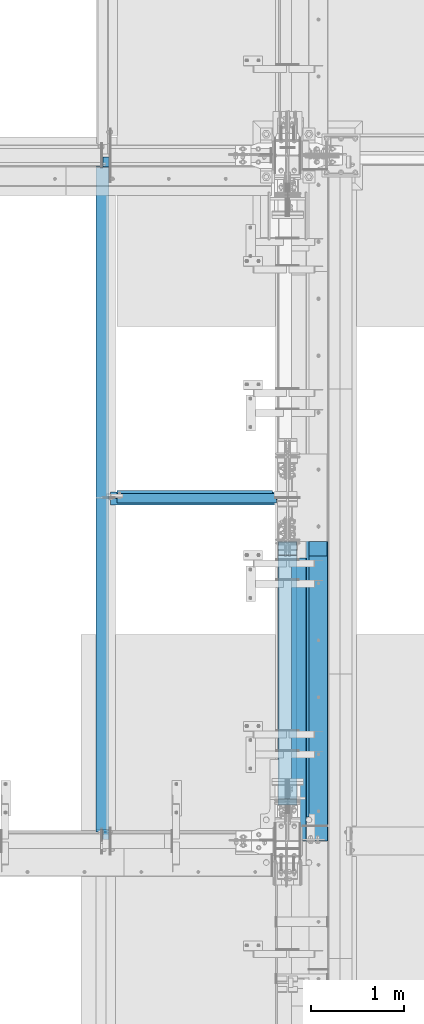
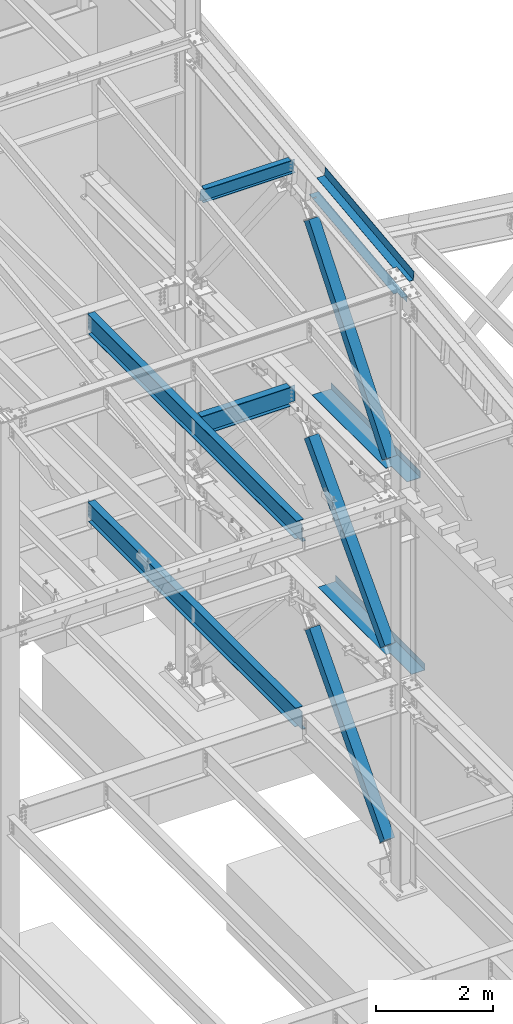
# One storey, part 741 of 1179: 8 beams, 3 members, 10 elements without a shape of their own.
"""IFC2X3 building model written with IfcOpenShell, lengths in millimetres."""

import ifcopenshell
import ifcopenshell.guid

model = None  # the IFC model being written
_history = None  # IfcOwnerHistory: only IFC2X3 demands one
_inside = {}  # id of a spatial element -> (the spatial element, [elements in it])
_under = {}  # id of a project, library or spatial element -> (it, [spatial elements below it])
_declared = {}  # id of a project -> (the project, [libraries it declares])
_typed = {}  # id of a type object -> (the type object, [elements of that type])
_made_of = {}  # id of a material, layer set ... -> (it, [elements and type objects made of it])


def new_model(schema):
    """Start an empty IFC model of exactly this schema.

    Asked for "IFC4X3", IfcOpenShell would pick the latest addendum, in which some entities
    have other attributes; the version numbers below select the first issue.
    IFC2X3 requires an IfcOwnerHistory on every rooted entity: one is made here for all.
    """
    global model, _history
    if schema == "IFC4X3":
        model = ifcopenshell.file(schema_version=(4, 3, 0, 0))
    else:
        model = ifcopenshell.file(schema=schema)
    _inside.clear()
    _under.clear()
    _declared.clear()
    _typed.clear()
    _made_of.clear()
    _history = None
    if model.schema == "IFC2X3":
        org = make("IfcOrganization", Name="unknown")
        user = make(
            "IfcPersonAndOrganization",
            ThePerson=make("IfcPerson", FamilyName="unknown"),
            TheOrganization=org,
        )
        app = make(
            "IfcApplication",
            ApplicationDeveloper=org,
            Version="unknown",
            ApplicationFullName="unknown",
            ApplicationIdentifier="unknown",
        )
        _history = make(
            "IfcOwnerHistory",
            OwningUser=user,
            OwningApplication=app,
            ChangeAction="ADDED",
            CreationDate=0,
        )
    return model


def make(cls, **values):
    """One entity of the class cls with the attributes given. An attribute that is None is left unset."""
    return model.create_entity(
        cls, **{name: value for name, value in values.items() if value is not None}
    )


def rooted(cls, **values):
    """An entity with a GlobalId (a new one), such as an element, a storey or a relation."""
    return make(cls, GlobalId=ifcopenshell.guid.new(), OwnerHistory=_history, **values)


def si_unit(unit_type, name, prefix=None):
    """IfcSIUnit, for example si_unit("LENGTHUNIT", "METRE", prefix="MILLI")."""
    return make("IfcSIUnit", UnitType=unit_type, Prefix=prefix, Name=name)


def assignment(units):
    """IfcUnitAssignment: the units of a project."""
    return None if units is None else make("IfcUnitAssignment", Units=units)


def point(xyz):
    """IfcCartesianPoint."""
    return None if xyz is None else make("IfcCartesianPoint", Coordinates=xyz)


def direction(xyz):
    """IfcDirection."""
    return None if xyz is None else make("IfcDirection", DirectionRatios=xyz)


def frame(location, z_axis=None, x_axis=None):
    """IfcAxis2Placement3D, a coordinate frame: its origin and axes. An axis left out is left unset."""
    return make(
        "IfcAxis2Placement3D",
        Location=point(location),
        Axis=direction(z_axis),
        RefDirection=direction(x_axis),
    )


def origin_with_axes():
    """The frame at (0, 0, 0) with the z axis (0, 0, 1) and the x axis (1, 0, 0) written out."""
    return frame((0.0, 0.0, 0.0), z_axis=(0.0, 0.0, 1.0), x_axis=(1.0, 0.0, 0.0))


def place(relative_to, where):
    """IfcLocalPlacement: puts the frame where relative to a parent placement (None: the world)."""
    return make(
        "IfcLocalPlacement", PlacementRelTo=relative_to, RelativePlacement=where
    )


def context(
    kind, dimensions, precision=None, world=None, true_north=None, identifier=None
):
    """IfcGeometricRepresentationContext, for example the 3D "Model" context."""
    return make(
        "IfcGeometricRepresentationContext",
        ContextIdentifier=identifier,
        ContextType=kind,
        CoordinateSpaceDimension=dimensions,
        Precision=precision,
        WorldCoordinateSystem=world,
        TrueNorth=true_north,
    )


def subcontext(parent, identifier, kind, view, scale=None):
    """IfcGeometricRepresentationSubContext, for example "Body" below "Model"."""
    return make(
        "IfcGeometricRepresentationSubContext",
        ContextIdentifier=identifier,
        ContextType=kind,
        ParentContext=parent,
        TargetScale=scale,
        TargetView=view,
    )


def project(units=None, contexts=None):
    """IfcProject with its units and contexts."""
    return rooted(
        "IfcProject",
        Name="project",
        RepresentationContexts=contexts,
        UnitsInContext=assignment(units),
    )


def spatial(cls, under=None, at=None, **own):
    """A site, building, storey or space (cls), placed at a placement, below another one or the project."""
    s = rooted(cls, ObjectPlacement=at, **own)
    if under is not None:
        _under.setdefault(under.id(), (under, []))[1].append(s)
    return s


def faces_of(points, faces, orient=None, outer=None):
    """IfcFace entities. A face is a list of loops; a loop is a list of indices into points, from 0.

    orient and outer hold one flag for each loop. By default every Orientation is true, the
    first loop of a face is its IfcFaceOuterBound and the others are IfcFaceBound.
    """
    made = []
    for i, loops in enumerate(faces):
        bounds = []
        for j, loop in enumerate(loops):
            is_outer = j == 0 if outer is None else outer[i][j]
            bounds.append(
                make(
                    "IfcFaceOuterBound" if is_outer else "IfcFaceBound",
                    Bound=make("IfcPolyLoop", Polygon=[points[k] for k in loop]),
                    Orientation=True if orient is None else orient[i][j],
                )
            )
        made.append(make("IfcFace", Bounds=bounds))
    return made


def faceted_brep(points, faces, orient=None, outer=None, voids=None):
    """IfcFacetedBrep: a solid bounded by flat faces; with voids (closed shells), ...WithVoids."""
    shared = [point(p) for p in points]
    hull = make("IfcClosedShell", CfsFaces=faces_of(shared, faces, orient, outer))
    if voids is None:
        return make("IfcFacetedBrep", Outer=hull)
    return make(
        "IfcFacetedBrepWithVoids",
        Outer=hull,
        Voids=[
            make(cls, CfsFaces=faces_of(shared, fs, o, b)) for cls, fs, o, b in voids
        ],
    )


def shape(context_of_items, identifier, shape_type, items):
    """IfcShapeRepresentation: the items that make up one representation, for example the "Body"."""
    return make(
        "IfcShapeRepresentation",
        ContextOfItems=context_of_items,
        RepresentationIdentifier=identifier,
        RepresentationType=shape_type,
        Items=items,
    )


def material(Name=None, Category=None):
    """IfcMaterial."""
    return make("IfcMaterial", Name=Name, Category=Category)


def made_of(thing, what):
    """Note that an element or type object is made of a material, layer set ...; save() writes the relation."""
    if what is not None:
        _made_of.setdefault(what.id(), (what, []))[1].append(thing)
    return thing


def type_object(cls, material=None, **own):
    """A type object (cls), such as IfcWallType, which elements share."""
    return made_of(rooted(cls, **own), material)


def element(
    cls,
    number,
    at=None,
    inside=None,
    cuts=None,
    type_object=None,
    material=None,
    context=None,
    identifier="Body",
    shape_type=None,
    held_by="IfcProductDefinitionShape",
    body=None,
    shapes=None,
    **own,
):
    """One element of the class cls, such as IfcWall. Its Tag is "e" and its number.

    at: its placement. inside: the storey or other place that contains it. cuts: it is an
    opening in that element (IfcRelVoidsElement). A single representation is given by context,
    identifier, shape_type and body (its items); several are given by shapes. held_by: the class
    of the entity that holds the representations. save() writes the other relations.
    """
    e = rooted(cls, Tag="e%d" % number, ObjectPlacement=at, **own)
    if body is not None:
        shapes = [shape(context, identifier, shape_type, body)]
    if shapes is not None:
        e.Representation = make(held_by, Representations=shapes)
    if inside is not None:
        _inside.setdefault(inside.id(), (inside, []))[1].append(e)
    if cuts is not None:
        rooted(
            "IfcRelVoidsElement", RelatingBuildingElement=cuts, RelatedOpeningElement=e
        )
    if type_object is not None:
        _typed.setdefault(type_object.id(), (type_object, []))[1].append(e)
    return made_of(e, material)


def aggregate(whole, parts):
    """IfcRelAggregates: a whole, such as a stair, and the parts it consists of."""
    return rooted("IfcRelAggregates", RelatingObject=whole, RelatedObjects=parts)


def save(model, path):
    """Write the relations noted so far, then the file.

    IfcRelAggregates (storeys below a building ...), IfcRelContainedInSpatialStructure (elements
    in a storey), IfcRelDefinesByType, IfcRelAssociatesMaterial and IfcRelDeclares: one each for
    every whole, place, type object, material and project.
    """
    for whole, parts in _under.values():
        aggregate(whole, parts)
    for where, things in _inside.values():
        rooted(
            "IfcRelContainedInSpatialStructure",
            RelatedElements=things,
            RelatingStructure=where,
        )
    for kind, things in _typed.values():
        rooted("IfcRelDefinesByType", RelatedObjects=things, RelatingType=kind)
    for what, things in _made_of.values():
        rooted("IfcRelAssociatesMaterial", RelatedObjects=things, RelatingMaterial=what)
    for by, libraries in _declared.values():
        rooted("IfcRelDeclares", RelatingContext=by, RelatedDefinitions=libraries)
    model.write(path)


model = new_model("IFC2X3")

# Units and contexts
model_context = context("Model", 3, precision=1e-05, world=origin_with_axes())
body_context = subcontext(model_context, "Body", "Model", "MODEL_VIEW")
ifc_project = project(units=[si_unit("LENGTHUNIT", "METRE", prefix="MILLI"), si_unit("AREAUNIT", "SQUARE_METRE"), si_unit("VOLUMEUNIT", "CUBIC_METRE"), si_unit("MASSUNIT", "GRAM", prefix="KILO"), si_unit("TIMEUNIT", "SECOND"), si_unit("PLANEANGLEUNIT", "RADIAN"), si_unit("SOLIDANGLEUNIT", "STERADIAN"), si_unit("THERMODYNAMICTEMPERATUREUNIT", "DEGREE_CELSIUS"), si_unit("LUMINOUSINTENSITYUNIT", "LUMEN")], contexts=[model_context])

# Site, building, storey
site_placement = place(None, origin_with_axes())
site = spatial("IfcSite", under=ifc_project, at=site_placement, CompositionType="ELEMENT")
building_placement = place(site_placement, origin_with_axes())
building = spatial("IfcBuilding", under=site, at=building_placement, Name="Undefined", CompositionType="ELEMENT")
storey_placement = place(building_placement, origin_with_axes())
storey = spatial("IfcBuildingStorey", under=building, at=storey_placement, Name="Undefined", CompositionType="ELEMENT", Elevation=0.0)

# Assembly, beam
assembly_1_placement = place(storey_placement, origin_with_axes())
assembly_1 = element("IfcElementAssembly", 1, at=assembly_1_placement, inside=storey, Name="BEAM", AssemblyPlace="NOTDEFINED", PredefinedType="RIGID_FRAME")
ifc_material_1 = material(Name="STEEL/A992")
beam_type_1 = type_object("IfcBeamType", Name="W16X31", PredefinedType="NOTDEFINED")
beam_1_placement = place(assembly_1_placement, frame((22326.6, 30721.3, 7812.0875), z_axis=(0.0, 0.0, 1.0), x_axis=(1.0, 0.0, 0.0)))
beam_1 = element("IfcBeam", 2, at=beam_1_placement, type_object=beam_type_1, material=ifc_material_1, Name="BEAM", ObjectType="W16X31", context=body_context, shape_type="Brep", body=[
    faceted_brep([(15.875, -3.17499999999927, -169.8625), (15.875, 3.17499999999927, -169.8625), (69.8500001907269, 3.17499999999927, -169.8625), (69.8500001907269, -3.17499999999927, -169.8625), (74.7100797087733, 3.17499999999927, -170.829229922588), (74.7100797087733, -3.17499999999927, -170.829229922588), (78.8302561769269, 3.17499999999927, -173.582243823066), (78.8302561769269, -3.17499999999927, -173.582243823066), (81.5832700774044, 3.17499999999927, -177.70242029122), (81.5832700774044, -3.17499999999927, -177.70242029122), (82.549999999992, -3.17499999999927, -182.562499809265), (82.549999999992, 3.17499999999927, -182.562499809265), (82.549999999992, 3.17499999999927, -190.5), (82.549999999992, 69.8499999999985, -190.5), (82.549999999992, 69.8499999999985, -201.6125), (82.549999999992, -69.8499999999985, -201.6125), (82.549999999992, -69.8499999999985, -190.5), (82.549999999992, -3.17499999999927, -190.5), (1839.11875, 69.8499999999985, 190.5), (1839.11875, 3.17499999999927, 190.5), (82.549999999992, 3.17499999999927, 190.5), (82.549999999992, 69.8499999999985, 190.5), (69.8500001907269, -3.17499999999927, 169.8625), (69.8500001907269, 3.17499999999927, 169.8625), (15.875, 3.17499999999927, 169.8625), (15.875, -3.17499999999927, 169.8625), (74.7100797087733, -3.17499999999927, 170.829229922588), (74.7100797087733, 3.17499999999927, 170.829229922588), (78.8302561769269, -3.17499999999927, 173.582243823066), (78.8302561769269, 3.17499999999927, 173.582243823066), (81.5832700774044, -3.17499999999927, 177.70242029122), (81.5832700774044, 3.17499999999927, 177.70242029122), (82.549999999992, -3.17499999999927, 182.562499809265), (82.549999999992, 3.17499999999927, 182.562499809265), (1839.11875, -69.8499999999985, 201.6125), (1839.11875, 69.8499999999985, 201.6125), (82.549999999992, 69.8499999999985, 201.6125), (82.549999999992, -69.8499999999985, 201.6125), (1839.11875, -69.8499999999985, 190.5), (82.549999999992, -69.8499999999985, 190.5), (1839.11875, -3.17499999999927, 190.5), (82.549999999992, -3.17499999999927, 190.5), (1839.11875, -3.17499999999927, 179.387499809265), (1839.11875, 3.17499999999927, 179.387499809265), (1840.08547992259, -3.17499999999927, 174.52742029122), (1840.08547992259, 3.17499999999927, 174.52742029122), (1842.83849382306, -3.17499999999927, 170.407243823066), (1842.83849382306, 3.17499999999927, 170.407243823066), (1846.95867029122, -3.17499999999927, 167.654229922588), (1846.95867029122, 3.17499999999927, 167.654229922588), (1851.81874980926, -3.17499999999927, 166.6875), (1851.81874980926, 3.17499999999927, 166.6875), (1962.94375, -3.17499999999927, 166.6875), (1962.94375, 3.17499999999927, 166.6875), (1962.94375, -3.17499999999927, -166.6875), (1962.94375, 3.17499999999927, -166.6875), (1851.81874980926, -3.17499999999927, -166.6875), (1851.81874980926, 3.17499999999927, -166.6875), (1846.95867029122, -3.17499999999927, -167.654229922588), (1846.95867029122, 3.17499999999927, -167.654229922588), (1842.83849382306, -3.17499999999927, -170.407243823066), (1842.83849382306, 3.17499999999927, -170.407243823066), (1840.08547992259, -3.17499999999927, -174.52742029122), (1840.08547992259, 3.17499999999927, -174.52742029122), (1839.11875, -3.17499999999927, -179.387499809265), (1839.11875, 3.17499999999927, -179.387499809265), (1839.11875, -3.17499999999927, -190.5), (1839.11875, -69.8499999999985, -190.5), (1839.11875, -69.8499999999985, -201.6125), (1839.11875, 69.8499999999985, -201.6125), (1839.11875, 69.8499999999985, -190.5), (1839.11875, 3.17499999999927, -190.5)], [[[0, 1, 2, 3]], [[3, 2, 4, 5]], [[5, 4, 6, 7]], [[7, 6, 8, 9]], [[10, 11, 12, 13, 14, 15, 16, 17]], [[9, 8, 11, 10]], [[18, 19, 20, 21]], [[22, 23, 24, 25]], [[26, 27, 23, 22]], [[28, 29, 27, 26]], [[30, 31, 29, 28]], [[32, 33, 31, 30]], [[34, 35, 36, 37]], [[38, 34, 37, 39]], [[40, 38, 39, 41]], [[37, 36, 21, 20, 33, 32, 41, 39]], [[35, 18, 21, 36]], [[34, 38, 40, 42, 43, 19, 18, 35]], [[44, 45, 43, 42]], [[46, 47, 45, 44]], [[48, 49, 47, 46]], [[50, 51, 49, 48]], [[52, 53, 51, 50]], [[53, 52, 54, 55]], [[54, 56, 57, 55]], [[58, 59, 57, 56]], [[60, 61, 59, 58]], [[62, 63, 61, 60]], [[64, 65, 63, 62]], [[66, 67, 68, 69, 70, 71, 65, 64]], [[67, 66, 17, 16]], [[68, 67, 16, 15]], [[69, 68, 15, 14]], [[70, 69, 14, 13]], [[71, 70, 13, 12]], [[6, 4, 2, 1, 24, 23, 27, 29, 31, 33, 20, 19, 43, 45, 47, 49, 51, 53, 55, 57, 59, 61, 63, 65, 71, 12, 11, 8]], [[25, 24, 1, 0]], [[66, 64, 62, 60, 58, 56, 54, 52, 50, 48, 46, 44, 42, 40, 41, 32, 30, 28, 26, 22, 25, 0, 3, 5, 7, 9, 10, 17]]]),
])
aggregate(assembly_1, [beam_1])

assembly_2_placement = place(storey_placement, origin_with_axes())
assembly_2 = element("IfcElementAssembly", 3, at=assembly_2_placement, inside=storey, Name="BEAM", AssemblyPlace="NOTDEFINED", PredefinedType="RIGID_FRAME")
beam_2_placement = place(assembly_2_placement, frame((22326.6, 27051.0, 7812.0875), z_axis=(0.0, 0.0, 1.0), x_axis=(0.0, 1.0, 0.0)))
beam_2 = element("IfcBeam", 4, at=beam_2_placement, type_object=beam_type_1, material=ifc_material_1, Name="BEAM", ObjectType="W16X31", context=body_context, shape_type="Brep", body=[
    faceted_brep([(82.5499999999993, -3.17500000000291, 166.6875), (82.5499999999993, 3.17500000000291, 166.6875), (17.4624999999942, 3.17499999999927, 166.6875), (17.4624999999942, -3.17499999999927, 166.6875), (87.4100797087813, -3.17499999999927, 167.654229922588), (87.4100797087813, 3.17497144083973, 167.654229922588), (91.5302561769349, -3.17499999999927, 170.407243823066), (91.5302561769349, 3.17496966460385, 170.407243823066), (94.2832700774125, -3.17499999999927, 174.52742029122), (94.2832700774125, 3.1749670062818, 174.52742029122), (95.25, -3.17499999999927, 179.387499809265), (95.25, 3.1749638705769, 179.387499809265), (95.25, -69.8499999999985, 201.6125), (95.25, 69.8499999999985, 201.6125), (95.25, 69.8499999999985, 190.5), (95.25, 3.17499999999927, 190.5), (95.25, -3.17499999999927, 190.5), (95.25, -69.8499999999985, 190.5), (7196.1375, 3.17499999999927, -190.5), (7196.1375, 69.8500000000004, -190.5), (144.462499999994, 69.8499999999985, -190.5), (144.462499999994, 3.17549991607666, -190.5), (17.4624999999942, -3.17499999999927, -190.5), (17.4624999999942, -69.8499999999985, -190.5), (7323.1375, -69.8500000000004, -190.5), (7323.1375, -3.17499999999927, -190.5), (17.4624999999942, -69.8499999999985, -201.6125), (7323.1375, -69.8500000000004, -201.6125), (7196.1375, 69.8500000000004, -201.6125), (7196.1375, 3.17549991607484, -201.6125), (7323.1375, 3.17549991607484, -201.6125), (17.4624999999942, 3.17549991607666, -201.6125), (144.462499999994, 3.17549991607666, -201.6125), (144.462499999994, 69.8499999999985, -201.6125), (17.4624999999942, 3.17499999999927, -190.5), (7323.1375, 3.17499999999927, -190.5), (7323.1375, 3.17499999999927, 166.6875), (7323.1375, -3.17499999999927, 166.6875), (7235.82499980928, 3.17499999999927, 166.6875), (7235.82499980928, -3.17499999999927, 166.6875), (7230.96492029123, 3.17499999999927, 167.654229922588), (7230.96492029123, -3.17499999999927, 167.654229922588), (7226.84474382308, 3.17499999999927, 170.407243823066), (7226.84474382308, -3.17499999999927, 170.407243823066), (7224.0917299226, 3.17499999999927, 174.52742029122), (7224.0917299226, -3.17499999999927, 174.52742029122), (7223.12500000001, 3.17499999999927, 179.387499809265), (7223.12500000001, -3.17499999999927, 179.387499809265), (7223.12500000001, -69.8500000000004, 201.6125), (7223.12500000001, -69.8500000000004, 190.5), (7223.12500000001, -3.17499999999927, 190.5), (7223.12500000001, 3.17499999999927, 190.5), (7223.12500000001, 69.8500000000004, 190.5), (7223.12500000001, 69.8500000000004, 201.6125)], [[[0, 1, 2, 3]], [[4, 5, 1, 0]], [[6, 7, 5, 4]], [[8, 9, 7, 6]], [[10, 11, 9, 8]], [[12, 13, 14, 15, 11, 10, 16, 17]], [[18, 19, 20, 21]], [[22, 23, 24, 25]], [[23, 26, 27, 24]], [[28, 29, 30, 27, 26, 31, 32, 33]], [[21, 32, 31, 34]], [[20, 33, 32, 21]], [[19, 28, 33, 20]], [[18, 29, 28, 19]], [[35, 30, 29, 18]], [[25, 24, 27, 30, 35, 36, 37]], [[37, 36, 38, 39]], [[39, 38, 40, 41]], [[41, 40, 42, 43]], [[43, 42, 44, 45]], [[45, 44, 46, 47]], [[48, 49, 50, 47, 46, 51, 52, 53]], [[49, 48, 12, 17]], [[50, 49, 17, 16]], [[8, 6, 4, 0, 3, 22, 25, 37, 39, 41, 43, 45, 47, 50, 16, 10]], [[34, 31, 26, 23, 22, 3, 2]], [[51, 46, 44, 42, 40, 38, 36, 35, 18, 21, 34, 2, 1, 5, 7, 9, 11, 15]], [[52, 51, 15, 14]], [[53, 52, 14, 13]], [[48, 53, 13, 12]]]),
])
aggregate(assembly_2, [beam_2])

assembly_3_placement = place(storey_placement, origin_with_axes())
assembly_3 = element("IfcElementAssembly", 5, at=assembly_3_placement, inside=storey, Name="BEAM", AssemblyPlace="NOTDEFINED", PredefinedType="RIGID_FRAME")
beam_3_placement = place(assembly_3_placement, frame((22326.6, 27051.0, 3900.4875), z_axis=(0.0, 0.0, 1.0), x_axis=(0.0, 1.0, 0.0)))
beam_3 = element("IfcBeam", 6, at=beam_3_placement, type_object=beam_type_1, material=ifc_material_1, Name="BEAM", ObjectType="W16X31", context=body_context, shape_type="Brep", body=[
    faceted_brep([(114.300000190742, -3.17499999999927, 169.8625), (114.300000190742, 3.17497080806788, 169.8625), (19.0500000762049, 3.17499999999382, 169.8625), (19.0499999238054, -3.17500000000564, 169.8625), (119.160079708789, -3.17499999999927, 170.829229922588), (119.160079708789, 3.17497018437643, 170.829229922588), (123.280256176942, -3.17499999999927, 173.582243823066), (123.280256176942, 3.1749684082497, 173.582243823066), (126.03327007742, -3.17499999999927, 177.70242029122), (126.03327007742, 3.17496575008772, 177.70242029122), (127.000000000007, -3.17499999999927, 182.562499809265), (127.000000000007, 3.174962614572, 182.562499809265), (127.000000000007, -69.8499999999985, 201.6125), (127.000000000007, 69.8499999999985, 201.6125), (127.000000000007, 69.8499999999985, 190.5), (127.000000000007, 3.17499999999927, 190.5), (127.000000000007, -3.17499999999927, 190.5), (127.000000000007, -69.8499999999985, 190.5), (7195.34375, 3.17499999999927, -190.5), (7195.34375, 69.8499999999985, -190.5), (146.049999999996, 69.8499999999985, -190.5), (146.049999999996, 3.17549991607666, -190.5), (19.0499999999993, -3.17499999999927, -190.5), (19.0499999999993, -69.8499999999985, -190.5), (7322.34375, -69.8499999999985, -190.5), (7322.34375, -3.17499999999927, -190.5), (19.0499999999993, -69.8499999999985, -201.6125), (7322.34375, -69.8499999999985, -201.6125), (7195.34375, 69.8499999999985, -201.6125), (7195.34375, 3.17549991607666, -201.6125), (7322.34375, 3.17549991607666, -201.6125), (19.0499999999993, 3.17549991607666, -201.6125), (146.049999999996, 3.17549991607666, -201.6125), (146.049999999996, 69.8499999999985, -201.6125), (19.0499999999993, 3.17499999999927, -190.5), (7322.34375, 3.17499999999927, -190.5), (7322.34375, 3.17499999999927, 169.8625), (7322.34375, -3.17499999999927, 169.8625), (7227.09374980925, 3.17499999999927, 169.8625), (7227.09374980925, -3.17499999999927, 169.8625), (7222.2336702912, 3.17499999999927, 170.829229922588), (7222.2336702912, -3.17499999999927, 170.829229922588), (7218.11349382305, 3.17499999999927, 173.582243823066), (7218.11349382305, -3.17499999999927, 173.582243823066), (7215.36047992257, 3.17499999999927, 177.70242029122), (7215.36047992257, -3.17499999999927, 177.70242029122), (7214.39374999998, 3.17499999999927, 182.562499809265), (7214.39374999998, -3.17499999999927, 182.562499809265), (7214.39374999998, -69.8499999999985, 201.6125), (7214.39374999998, -69.8499999999985, 190.5), (7214.39374999998, -3.17499999999927, 190.5), (7214.39374999998, 3.17499999999927, 190.5), (7214.39374999998, 69.8499999999985, 190.5), (7214.39374999998, 69.8499999999985, 201.6125)], [[[0, 1, 2, 3]], [[4, 5, 1, 0]], [[6, 7, 5, 4]], [[8, 9, 7, 6]], [[10, 11, 9, 8]], [[12, 13, 14, 15, 11, 10, 16, 17]], [[18, 19, 20, 21]], [[22, 23, 24, 25]], [[23, 26, 27, 24]], [[28, 29, 30, 27, 26, 31, 32, 33]], [[21, 32, 31, 34]], [[20, 33, 32, 21]], [[19, 28, 33, 20]], [[18, 29, 28, 19]], [[35, 30, 29, 18]], [[25, 24, 27, 30, 35, 36, 37]], [[37, 36, 38, 39]], [[39, 38, 40, 41]], [[41, 40, 42, 43]], [[43, 42, 44, 45]], [[45, 44, 46, 47]], [[48, 49, 50, 47, 46, 51, 52, 53]], [[49, 48, 12, 17]], [[50, 49, 17, 16]], [[8, 6, 4, 0, 3, 22, 25, 37, 39, 41, 43, 45, 47, 50, 16, 10]], [[34, 31, 26, 23, 22, 3, 2]], [[51, 46, 44, 42, 40, 38, 36, 35, 18, 21, 34, 2, 1, 5, 7, 9, 11, 15]], [[52, 51, 15, 14]], [[53, 52, 14, 13]], [[48, 53, 13, 12]]]),
])
aggregate(assembly_3, [beam_3])

assembly_4_placement = place(storey_placement, origin_with_axes())
assembly_4 = element("IfcElementAssembly", 7, at=assembly_4_placement, inside=storey, Name="BEAM", AssemblyPlace="NOTDEFINED", PredefinedType="RIGID_FRAME")
ifc_material_2 = material(Name="STEEL/A36")
beam_type_2 = type_object("IfcBeamType", PredefinedType="NOTDEFINED")
beam_4_placement = place(assembly_4_placement, frame((24350.663, 28568.0759537217, 12478.2300352794), z_axis=(0.0, -0.993676146336441, -0.112284087038017), x_axis=(1.0, 0.0, 0.0)))
beam_4 = element("IfcBeam", 8, at=beam_4_placement, type_object=beam_type_2, material=ifc_material_2, Name="BENT_PLATE", context=body_context, shape_type="Brep", body=[
    faceted_brep([(71.4353392469493, -3.17499183979635, 1106.25843673032), (71.4353734329561, 3.17500000044674, 1106.25969803081), (-1.45519152283669e-11, 3.17500000044674, 1106.25971229754), (-1.45519152283669e-11, -3.17499999954816, 1106.25845107343), (71.4348572723429, -3.25795320497673, 1523.92576177066), (71.4348919050608, 3.17500000061591, 1523.99999999914), (160.337000000047, -3.17500000061591, -1523.99999999915), (0.0, -3.17499999999927, -1524.0), (0.0, 3.17499999999927, -1524.0), (153.987000022519, 3.17500000077052, -1524.00000000059), (153.987000000016, 187.324999998867, -1523.99999999923), (160.337000000014, 187.324999998867, -1523.99999999923), (153.987000024775, 3.17499999922438, 1524.00000000046), (153.987000000016, 187.325000000103, 1523.99999999907), (160.337000000014, 187.325000000103, 1523.99999999907), (160.336999999981, -3.17499999938082, 1523.99999999915)], [[[0, 1, 2, 3]], [[4, 5, 1, 0]], [[6, 7, 8, 9, 10, 11]], [[9, 12, 13, 10]], [[14, 11, 10, 13]], [[15, 6, 11, 14]], [[3, 7, 6, 15, 4, 0]], [[8, 7, 3, 2]], [[12, 9, 8, 2, 1, 5]], [[15, 14, 13, 12, 5, 4]]]),
])

# Assembly, member
assembly_5_placement = place(storey_placement, origin_with_axes())
assembly_5 = element("IfcElementAssembly", 9, at=assembly_5_placement, inside=storey, Name="None", AssemblyPlace="NOTDEFINED", PredefinedType="RIGID_FRAME")
member_type = type_object("IfcMemberType", Name="HSS8X8X3/16", PredefinedType="NOTDEFINED")
member_1_placement = place(assembly_5_placement, frame((24307.8, 27518.3552120458, 8394.70378914468), z_axis=(1.0, 0.0, 0.0), x_axis=(0.0, 0.62056699824227, 0.78415342930614)))
member_1 = element("IfcMember", 10, at=member_1_placement, type_object=member_type, material=ifc_material_1, Name="None", ObjectType="HSS8X8X3/16", context=body_context, shape_type="Brep", body=[
    faceted_brep([(-3.63797880709171e-12, 96.8374999999978, -96.8375000000015), (-3.63797880709171e-12, -96.8374999999978, -96.8375000000015), (4291.32999998814, -96.8374999960452, -96.8375), (4291.32999998818, 96.8375000037358, -96.8375), (-3.63797880709171e-12, -96.8374999999978, 96.8375000000015), (4291.32999998814, -96.8374999960452, 96.8375), (-3.63797880709171e-12, 96.8374999999978, 96.8375000000015), (4291.32999998818, 96.8375000037358, 96.8375), (-3.63797880709171e-12, 101.599999999999, -101.599999999999), (-3.63797880709171e-12, 101.599999999999, 101.599999999999), (4291.32999998818, 101.600000003729, 101.6), (4291.32999998818, 101.600000003729, -101.6), (0.0, -101.599999999999, 101.599999999999), (4291.32999998813, -101.599999996035, 101.6), (0.0, -101.599999999999, -101.599999999999), (4291.32999998813, -101.599999996035, -101.6)], [[[0, 1, 2, 3]], [[1, 4, 5, 2]], [[4, 6, 7, 5]], [[6, 0, 3, 7]], [[8, 9, 10, 11]], [[9, 12, 13, 10]], [[12, 14, 15, 13]], [[14, 8, 11, 15]], [[13, 15, 11, 10], [5, 7, 3, 2]], [[14, 12, 9, 8], [6, 4, 1, 0]]]),
])
aggregate(assembly_5, [member_1])

assembly_6_placement = place(storey_placement, origin_with_axes())
assembly_6 = element("IfcElementAssembly", 11, at=assembly_6_placement, inside=storey, Name="None", AssemblyPlace="NOTDEFINED", PredefinedType="RIGID_FRAME")
member_2_placement = place(assembly_6_placement, frame((24307.8, 27577.7634105926, 4453.94491507657), z_axis=(1.0, 0.0, 0.0), x_axis=(0.0, 0.684256097894612, 0.729241792887681)))
member_2 = element("IfcMember", 12, at=member_2_placement, type_object=member_type, material=ifc_material_1, Name="None", ObjectType="HSS8X8X3/16", context=body_context, shape_type="Brep", body=[
    faceted_brep([(-3.63797880709171e-12, 96.8374999999978, -96.8375000000015), (-3.63797880709171e-12, -96.8374999999978, -96.8375000000015), (3806.84458407234, -96.837499991303, -96.8375), (3806.84458407192, 96.8375000092055, -96.8375), (-3.63797880709171e-12, -96.8374999999978, 96.8375000000015), (3806.84458407234, -96.837499991303, 96.8375), (-3.63797880709171e-12, 96.8374999999978, 96.8375000000015), (3806.84458407192, 96.8375000092055, 96.8375), (-3.63797880709171e-12, 101.599999999999, -101.599999999999), (-3.63797880709171e-12, 101.599999999999, 101.599999999999), (3806.84458407191, 101.600000009224, 101.6), (3806.84458407191, 101.600000009224, -101.6), (0.0, -101.599999999999, 101.599999999999), (3806.84458407235, -101.599999991318, 101.6), (0.0, -101.599999999999, -101.599999999999), (3806.84458407235, -101.599999991318, -101.6)], [[[0, 1, 2, 3]], [[1, 4, 5, 2]], [[4, 6, 7, 5]], [[6, 0, 3, 7]], [[8, 9, 10, 11]], [[9, 12, 13, 10]], [[12, 14, 15, 13]], [[14, 8, 11, 15]], [[13, 15, 11, 10], [5, 7, 3, 2]], [[14, 12, 9, 8], [6, 4, 1, 0]]]),
])
aggregate(assembly_6, [member_2])

assembly_7_placement = place(storey_placement, origin_with_axes())
assembly_7 = element("IfcElementAssembly", 13, at=assembly_7_placement, inside=storey, Name="None", AssemblyPlace="NOTDEFINED", PredefinedType="RIGID_FRAME")
member_3_placement = place(assembly_7_placement, frame((24307.8, 27591.4450247985, 389.061818198374), z_axis=(1.0, 0.0, 0.0), x_axis=(0.0, 0.666221892712437, 0.74575357167811)))
member_3 = element("IfcMember", 14, at=member_3_placement, type_object=member_type, material=ifc_material_1, Name="None", ObjectType="HSS8X8X3/16", context=body_context, shape_type="Brep", body=[
    faceted_brep([(-3.63797880709171e-12, 96.8374999999978, -96.8375000000015), (-3.63797880709171e-12, -96.8374999999978, -96.8375000000015), (3848.73500006714, -96.837500009533, -96.8375000000015), (3848.73500006755, 96.8374999900007, -96.8375000000015), (-3.63797880709171e-12, -96.8374999999978, 96.8375000000015), (3848.73500006714, -96.837500009533, 96.8375000000015), (-3.63797880709171e-12, 96.8374999999978, 96.8375000000015), (3848.73500006755, 96.8374999900007, 96.8375000000015), (-3.63797880709171e-12, 101.599999999999, -101.599999999999), (-3.63797880709171e-12, 101.599999999999, 101.599999999999), (3848.73500006757, 101.599999989987, 101.599999999999), (3848.73500006757, 101.599999989987, -101.599999999999), (0.0, -101.599999999999, 101.599999999999), (3848.73500006713, -101.600000009519, 101.599999999999), (0.0, -101.599999999999, -101.599999999999), (3848.73500006713, -101.600000009519, -101.599999999999)], [[[0, 1, 2, 3]], [[1, 4, 5, 2]], [[4, 6, 7, 5]], [[6, 0, 3, 7]], [[8, 9, 10, 11]], [[9, 12, 13, 10]], [[12, 14, 15, 13]], [[14, 8, 11, 15]], [[13, 15, 11, 10], [5, 7, 3, 2]], [[14, 12, 9, 8], [6, 4, 1, 0]]]),
])
aggregate(assembly_7, [member_3])

# Beam
beam_type_3 = type_object("IfcBeamType", PredefinedType="NOTDEFINED")
beam_5_placement = place(assembly_4_placement, frame((24350.6629997712, 28826.0689489842, 11978.5769225842), z_axis=(0.0, -0.993676146336441, -0.112284087038017), x_axis=(1.0, 0.0, 0.0)))
beam_5 = element("IfcBeam", 15, at=beam_5_placement, type_object=beam_type_3, material=ifc_material_2, Name="BENT_PLATE", context=body_context, shape_type="Brep", body=[
    faceted_brep([(76.1995002283802, -3.17517287870396, -1413.78096947271), (76.1995002283802, 3.17544073511635, -1413.7809694727), (0.0, 3.17499999942629, -1413.7809694727), (0.0, -3.17500000057044, -1413.7809694727), (76.1995002283802, -3.17517287869487, -1397.90596947287), (76.1995002283802, 3.17544073511999, -1397.90596947289), (0.0, -3.17500000056134, -1397.90596947287), (0.0, 3.17499999943357, -1397.90596947289), (179.387000000001, -3.17499999999927, 1524.0), (179.387000000001, -3.17499999999927, -1524.0), (179.387000202249, -136.524999793119, -1523.99999999991), (179.38700020294, -136.524999792508, 1523.99999999976), (76.1995002269396, -3.17510786902676, 1377.94999996143), (76.1995002269396, 3.17550574472261, 1377.94999996396), (7.27595761418343e-12, 3.17500000055588, 1377.94999996396), (7.27595761418343e-12, -3.1749999994372, 1377.94999996142), (76.1995002269396, -3.17561361185653, 1523.999999945), (76.1995002269396, 3.17500000061045, 1523.99999999914), (185.737000202938, -136.524999792508, 1523.99999999976), (185.737000000001, 3.17499999999927, 1524.0), (185.737000000001, 3.17499999999927, -1524.0), (185.737000202247, -136.524999793119, -1523.99999999991), (0.0, -3.17499999999927, -1524.0), (0.0, 3.17499999999927, -1524.0)], [[[0, 1, 2, 3]], [[4, 5, 1, 0]], [[6, 7, 5, 4]], [[8, 9, 10, 11]], [[12, 13, 14, 15]], [[16, 17, 13, 12]], [[8, 11, 18, 19, 17, 16]], [[20, 19, 18, 21]], [[11, 10, 21, 18]], [[9, 22, 23, 20, 21, 10]], [[23, 22, 3, 2]], [[14, 13, 17, 19, 20, 23, 2, 1, 5, 7]], [[15, 14, 7, 6]], [[3, 22, 9, 8, 16, 12, 15, 6, 4, 0]]]),
])

aggregate(assembly_4, [beam_4, beam_5])

# Assembly, beam
assembly_8_placement = place(storey_placement, origin_with_axes())
assembly_8 = element("IfcElementAssembly", 16, at=assembly_8_placement, inside=storey, Name="BEAM", AssemblyPlace="NOTDEFINED", PredefinedType="RIGID_FRAME")
beam_type_4 = type_object("IfcBeamType", PredefinedType="NOTDEFINED")
beam_6_placement = place(assembly_8_placement, frame((24387.175012207, 28578.175, 4105.275), z_axis=(0.0, -1.0, 0.0), x_axis=(1.0, 0.0, 0.0)))
beam_6 = element("IfcBeam", 17, at=beam_6_placement, type_object=beam_type_4, material=ifc_material_2, Name="BENT_PLATE", context=body_context, shape_type="Brep", body=[
    faceted_brep([(84.1374893188477, -3.17500000000018, 801.466996577077), (84.1374893188477, 3.17500000000018, 801.466996577077), (0.0, 3.17500000000018, 801.466996577077), (0.0, -3.17500000000018, 801.466996577077), (84.1374893188477, -3.17500000000018, 1524.0), (84.1374893188477, 3.17500000000018, 1524.0), (352.424987792969, -3.17499999999927, -1524.0), (0.0, -3.17499999999927, -1524.0), (0.0, 3.17499999999927, -1524.0), (346.07498779297, 3.17500000000109, -1524.0), (346.07498779297, 130.175006103515, -1524.0), (352.424987792969, 130.175006103515, -1524.0), (346.07498779297, 3.17500000000109, 1524.0), (346.07498779297, 130.175006103515, 1524.0), (352.424987792969, 130.175006103515, 1524.0), (352.424987792969, -3.17499999999927, 1524.0)], [[[0, 1, 2, 3]], [[4, 5, 1, 0]], [[6, 7, 8, 9, 10, 11]], [[9, 12, 13, 10]], [[14, 11, 10, 13]], [[15, 6, 11, 14]], [[3, 7, 6, 15, 4, 0]], [[8, 7, 3, 2]], [[12, 9, 8, 2, 1, 5]], [[15, 14, 13, 12, 5, 4]]]),
])
aggregate(assembly_8, [beam_6])

assembly_9_placement = place(storey_placement, origin_with_axes())
assembly_9 = element("IfcElementAssembly", 18, at=assembly_9_placement, inside=storey, Name="BEAM", AssemblyPlace="NOTDEFINED", PredefinedType="RIGID_FRAME")
beam_type_5 = type_object("IfcBeamType", PredefinedType="NOTDEFINED")
beam_7_placement = place(assembly_9_placement, frame((24361.7750056992, 28733.7499996401, 8018.4625), z_axis=(0.0, 1.0, 0.0), x_axis=(1.0, 0.0, 0.0)))
beam_7 = element("IfcBeam", 19, at=beam_7_placement, type_object=beam_type_5, material=ifc_material_2, Name="BENT_PLATE", context=body_context, shape_type="Brep", body=[
    faceted_brep([(109.537494063061, -4.7624999831387, -991.216176709597), (109.537494215459, 4.76250001686094, -991.216176709597), (109.537490972511, 4.76250001686094, -1523.9999999999), (109.537490820112, -4.7624999831387, -1523.9999999999), (1.61890056915581e-09, -4.76249999999982, -991.216176371439), (1.52795109897852e-10, 4.76249999999982, -991.216176371439), (377.825003224127, 4.76250005815837, 1524.00000000034), (2.91038304567337e-11, 4.76250000000073, 1524.0), (-2.91038304567337e-11, -4.76250000000073, 1524.0), (368.300003071738, -4.76249994330828, 1524.00000000033), (368.300001090651, -128.587512142843, 1524.00000000033), (377.825001090652, -128.587512295235, 1524.00000000034), (377.825003226844, 4.76250005815837, -1523.99999999966), (377.82500109337, -128.587512295235, -1523.99999999966), (368.300001093368, -128.587512142843, -1523.99999999967), (368.300003074455, -4.76249994330828, -1523.99999999967)], [[[0, 1, 2, 3]], [[4, 5, 1, 0]], [[6, 7, 8, 9, 10, 11]], [[12, 6, 11, 13]], [[10, 14, 13, 11]], [[9, 15, 14, 10]], [[12, 13, 14, 15, 3, 2]], [[7, 6, 12, 2, 1, 5]], [[8, 7, 5, 4]], [[15, 9, 8, 4, 0, 3]]]),
])
aggregate(assembly_9, [beam_7])

assembly_10_placement = place(storey_placement, origin_with_axes())
assembly_10 = element("IfcElementAssembly", 20, at=assembly_10_placement, inside=storey, Name="BEAM", AssemblyPlace="NOTDEFINED", PredefinedType="RIGID_FRAME")
beam_type_6 = type_object("IfcBeamType", Name="W12X22", PredefinedType="NOTDEFINED")
beam_8_placement = place(assembly_10_placement, frame((22415.5, 30738.7779321232, 12563.7561799803), z_axis=(0.0, -0.112284087038017, 0.993676146336441), x_axis=(1.0, 0.0, 0.0)))
beam_8 = element("IfcBeam", 21, at=beam_8_placement, type_object=beam_type_6, material=ifc_material_1, Name="BEAM", ObjectType="W12X22", context=body_context, shape_type="Brep", body=[
    faceted_brep([(15.875, -3.17500000004293, -130.175000001276), (15.875, 3.17499999995198, -130.175000001278), (50.8000001907349, 3.17499998291896, -130.175000001278), (50.8000001907349, -3.17500000004293, -130.175000001276), (55.6600797087813, 3.17499998284256, -131.141729923866), (55.6600797087813, -3.17500000004293, -131.141729923862), (59.7802561769349, 3.17499998263156, -133.894743824338), (59.7802561769349, -3.17500000004293, -133.894743824334), (62.5332700774125, 3.17499998230778, -138.014920292484), (62.5332700774125, -3.17500000004657, -138.014920292482), (63.5, -3.17500000004657, -142.874999810521), (63.5, 3.17499998193671, -142.874999810523), (63.5, 3.17499995250182, -144.46249999992), (63.5, 50.7999999999192, -144.46249999994), (63.5, 50.7999999999156, -155.574999999932), (63.5, -50.8000000000284, -155.574999999892), (63.5, -50.8000000000247, -144.462499999896), (63.5, -3.1750000000502, -144.462499999914), (1732.75625, 3.17499999994834, -144.46249999992), (1732.75625, 3.17499999999563, -155.574999999912), (1732.75625, 50.7999999999156, -155.574999999932), (1732.75625, 50.7999999999192, -144.46249999994), (1872.45625, 3.17499999994834, -144.46249999992), (1872.45625, 3.17499999999563, -155.574999999912), (1770.85625, 50.8000000000357, 144.4624999999), (1770.85625, 3.17500000006476, 144.462499999918), (63.5, 3.17500000006476, 144.462499999918), (63.5, 50.8000000000357, 144.4624999999), (50.8000001907349, -3.17499999994106, 130.174999998288), (50.8000001907349, 3.17500000292785, 130.174999998286), (15.875, 3.17500000005748, 130.174999998284), (15.875, -3.17499999994106, 130.174999998288), (55.6600797087813, -3.17499999993379, 131.141729920873), (55.6600797087813, 3.17500000300424, 131.141729920872), (59.7802561769349, -3.17499999993743, 133.894743821347), (59.7802561769349, 3.17500000321525, 133.894743821344), (62.5332700774125, -3.17499999993379, 138.014920289494), (62.5332700774125, 3.17500000353539, 138.014920289492), (63.5, -3.17499999993015, 142.874999807531), (63.5, 3.1750000039101, 142.874999807529), (1770.85625, -50.799999999901, 155.574999999935), (1770.85625, 50.8000000000429, 155.574999999893), (63.5, 50.8000000000429, 155.574999999893), (63.5, -50.799999999901, 155.574999999935), (1770.85625, -50.7999999999047, 144.462499999941), (63.5, -50.7999999999047, 144.462499999941), (1770.85625, -3.17499999993379, 144.462499999923), (63.5, -3.17499999993379, 144.462499999923), (1770.85625, -3.17499999993743, 130.174999807548), (1770.85625, 3.17500000005748, 130.174999807547), (1771.82297992259, -3.17499999993743, 125.314920289511), (1771.82297992259, 3.17500000005748, 125.314920289509), (1774.57599382307, -3.1749999999447, 121.194743821365), (1774.57599382307, 3.17500000005384, 121.194743821363), (1778.69617029122, -3.1749999999447, 118.441729920891), (1778.69617029122, 3.17500000005384, 118.441729920889), (1783.55624980927, -3.1749999999447, 117.474999998307), (1783.55624980927, 3.17500000005384, 117.474999998303), (1872.45625, -3.1749999999447, 117.474999998307), (1872.45625, 3.17500000005384, 117.474999998303), (1872.45625, -3.1750000000502, -144.462499999914), (1872.45625, -50.8000000000247, -144.462499999896), (1872.45625, -50.8000000000284, -155.574999999892)], [[[0, 1, 2, 3]], [[3, 2, 4, 5]], [[5, 4, 6, 7]], [[7, 6, 8, 9]], [[10, 11, 12, 13, 14, 15, 16, 17]], [[9, 8, 11, 10]], [[18, 19, 20, 21]], [[22, 23, 19, 18]], [[24, 25, 26, 27]], [[28, 29, 30, 31]], [[32, 33, 29, 28]], [[34, 35, 33, 32]], [[36, 37, 35, 34]], [[38, 39, 37, 36]], [[40, 41, 42, 43]], [[44, 40, 43, 45]], [[46, 44, 45, 47]], [[43, 42, 27, 26, 39, 38, 47, 45]], [[41, 24, 27, 42]], [[40, 44, 46, 48, 49, 25, 24, 41]], [[50, 51, 49, 48]], [[52, 53, 51, 50]], [[54, 55, 53, 52]], [[56, 57, 55, 54]], [[58, 59, 57, 56]], [[60, 61, 62, 23, 22, 59, 58]], [[61, 60, 17, 16]], [[62, 61, 16, 15]], [[20, 19, 23, 62, 15, 14]], [[21, 20, 14, 13]], [[18, 21, 13, 12]], [[6, 4, 2, 1, 30, 29, 33, 35, 37, 39, 26, 25, 49, 51, 53, 55, 57, 59, 22, 18, 12, 11, 8]], [[31, 30, 1, 0]], [[60, 58, 56, 54, 52, 50, 48, 46, 47, 38, 36, 34, 32, 28, 31, 0, 3, 5, 7, 9, 10, 17]]]),
])
aggregate(assembly_10, [beam_8])

save(model, "model.ifc")
